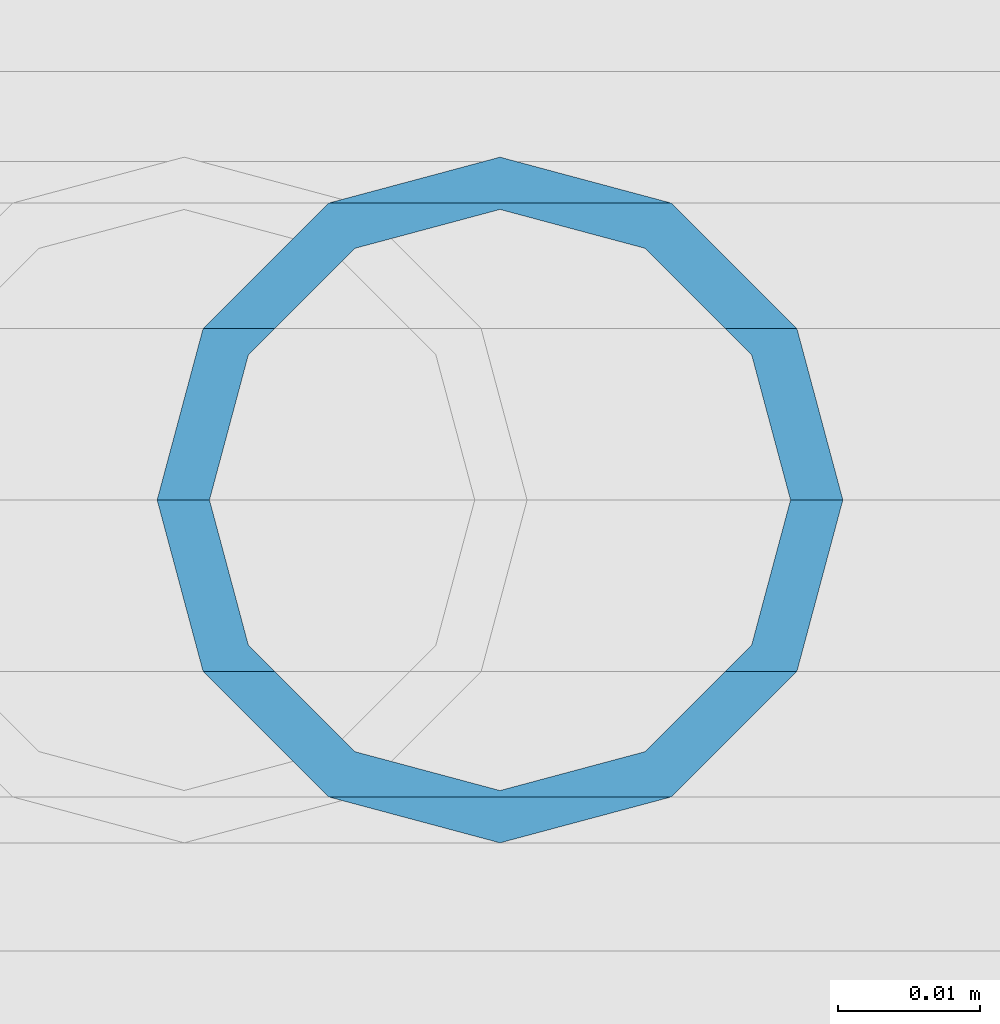
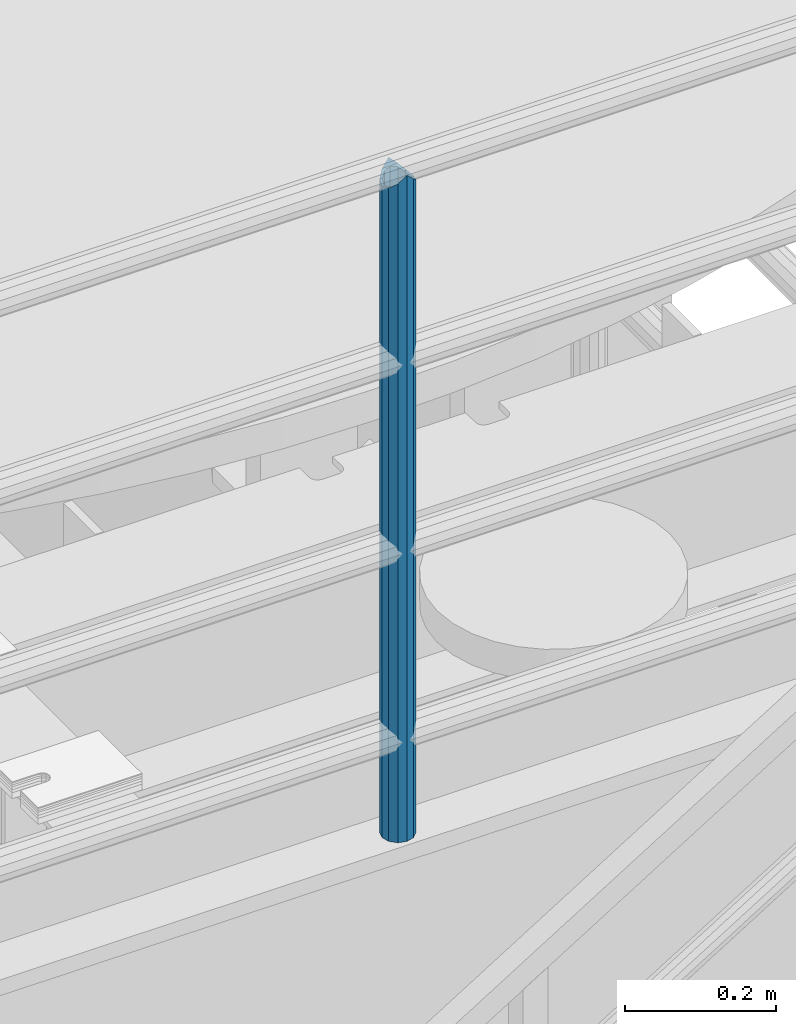
# One storey, part 629 of 1876: 1 column, 1 element without a shape of its own.
"""IFC2X3 building model written with IfcOpenShell, lengths in millimetres."""

from ifc_helpers import new_model, si_unit, frame, origin_with_axes, place, context, subcontext, project, spatial, faceted_brep, material, type_object, element, aggregate, save


model = new_model("IFC2X3")

# Units and contexts
model_context = context("Model", 3, precision=1e-05, world=origin_with_axes())
body_context = subcontext(model_context, "Body", "Model", "MODEL_VIEW")
ifc_project = project(units=[si_unit("LENGTHUNIT", "METRE", prefix="MILLI"), si_unit("AREAUNIT", "SQUARE_METRE"), si_unit("VOLUMEUNIT", "CUBIC_METRE"), si_unit("MASSUNIT", "GRAM", prefix="KILO"), si_unit("TIMEUNIT", "SECOND"), si_unit("PLANEANGLEUNIT", "RADIAN"), si_unit("SOLIDANGLEUNIT", "STERADIAN"), si_unit("THERMODYNAMICTEMPERATUREUNIT", "DEGREE_CELSIUS"), si_unit("LUMINOUSINTENSITYUNIT", "LUMEN")], contexts=[model_context])

# Site, building, storey
site_placement = place(None, origin_with_axes())
site = spatial("IfcSite", under=ifc_project, at=site_placement, CompositionType="ELEMENT")
building_placement = place(site_placement, origin_with_axes())
building = spatial("IfcBuilding", under=site, at=building_placement, Name="Undefined", CompositionType="ELEMENT")
storey_placement = place(building_placement, origin_with_axes())
storey = spatial("IfcBuildingStorey", under=building, at=storey_placement, Name="Undefined", CompositionType="ELEMENT", Elevation=0.0)

# Assembly, column
assembly_placement = place(storey_placement, origin_with_axes())
assembly = element("IfcElementAssembly", 1, at=assembly_placement, inside=storey, Name="RAIL", AssemblyPlace="NOTDEFINED", PredefinedType="RIGID_FRAME")
ifc_material = material()
column_type = type_object("IfcColumnType", Name="PIPE1-1/2SCH40", PredefinedType="NOTDEFINED")
column_placement = place(assembly_placement, frame((3959.22499997645, -4654.55000114554, 17983.2), z_axis=(0.0, 1.0, 0.0), x_axis=(0.0, 0.0, 1.0)))
column = element("IfcColumn", 2, at=column_placement, type_object=column_type, material=ifc_material, Name="POST", ObjectType="PIPE1-1/2SCH40", context=body_context, shape_type="Brep", body=[
    faceted_brep([(1076.325, 0.0, -24.1300000000001), (1064.26, 12.065, -20.8971929933186), (1064.26, -12.0650000000001, -20.8971929933186), (1054.93437856882, 17.7076214311801, 10.2235000000001), (1052.195, 20.4470000000001, 0.0), (1052.195, 24.13, 0.0), (1055.42780700668, 20.8971929933185, 12.0649999999996), (1055.42780700668, 15.8661214311869, 12.0649999999932), (1055.42780700668, 15.8661214311742, -12.065000000006), (1055.42780700668, 20.8971929933185, -12.0649999999996), (1054.93437856882, 17.7076214311801, -10.2235000000001), (1061.07042843786, 10.2235000000001, -17.7076214311801), (1063.80980700668, 0.0, -20.4470000000001), (1061.07042843786, -10.2235000000001, -17.7076214311801), (1055.42780700668, -15.8661214311742, -12.065000000006), (1055.42780700668, -20.8971929933184, -12.0649999999996), (1054.93437856882, -17.7076214311801, -10.2235000000001), (1052.195, -20.4470000000001, 0.0), (1052.195, -24.1300000000001, 0.0), (1054.93437856882, -17.7076214311801, 10.2235000000001), (1055.42780700668, -15.8661214311869, 12.0649999999932), (1055.42780700668, -20.8971929933184, 12.0649999999996), (1076.325, 0.0, 24.1300000000001), (1064.26, -12.0650000000001, 20.8971929933186), (1064.26, 12.065, 20.8971929933186), (1061.07042843787, -10.2235000000001, 17.7076214311801), (1063.80980700669, 0.0, 20.4470000000001), (1061.07042843787, 10.2235000000001, 17.7076214311801), (0.0, -20.8971929933184, -12.0649999999996), (0.0, -12.0650000000001, -20.8971929933186), (-1.45519152283669e-11, 0.0, -24.130000000001), (0.0, 12.0650000000001, -20.8971929933186), (0.0, 20.8971929933184, -12.0649999999996), (0.0, 24.1299999999992, 0.0), (0.0, 20.8971929933184, 12.0649999999996), (0.0, 12.0650000000001, 20.8971929933186), (-1.45519152283669e-11, 0.0, 24.130000000001), (0.0, -20.8971929933184, 12.0649999999996), (0.0, -24.1299999999992, 0.0), (0.0, -12.0650000000001, 20.8971929933186), (0.0, -17.7076214311803, -10.2235000000001), (0.0, -10.2235000000001, -17.7076214311801), (-1.45519152283669e-11, 0.0, -20.4470000000001), (0.0, 10.2235000000001, -17.7076214311801), (0.0, 17.7076214311803, -10.2235000000001), (0.0, 20.4469999999999, 0.0), (0.0, 17.7076214311803, 10.2235000000001), (0.0, 10.2235000000001, 17.7076214311801), (-1.45519152283669e-11, 0.0, 20.4470000000001), (0.0, -10.2235000000001, 17.7076214311801), (0.0, -17.7076214311803, 10.2235000000001), (0.0, -20.4469999999999, 0.0)], [[[0, 1, 2]], [[3, 4, 5, 6, 7]], [[8, 9, 5, 4, 10]], [[2, 1, 9, 8, 11, 12, 13, 14, 15]], [[15, 14, 16, 17, 18]], [[18, 17, 19, 20, 21]], [[22, 23, 24]], [[21, 20, 25, 26, 27, 7, 6, 24, 23]], [[28, 29, 2, 15]], [[29, 30, 0, 2]], [[30, 31, 1, 0]], [[31, 32, 9, 1]], [[32, 33, 5, 9]], [[33, 34, 6, 5]], [[34, 35, 24, 6]], [[35, 36, 22, 24]], [[37, 38, 18, 21]], [[39, 37, 21, 23]], [[36, 39, 23, 22]], [[38, 28, 15, 18]], [[37, 39, 36, 35, 34, 33, 32, 31, 30, 29, 28, 38], [40, 41, 42, 43, 44, 45, 46, 47, 48, 49, 50, 51]], [[49, 48, 26, 25]], [[19, 50, 49, 25, 20]], [[51, 50, 19, 17]], [[40, 51, 17, 16]], [[41, 40, 16, 14, 13]], [[42, 41, 13, 12]], [[43, 42, 12, 11]], [[10, 44, 43, 11, 8]], [[45, 44, 10, 4]], [[46, 45, 4, 3]], [[47, 46, 3, 7, 27]], [[48, 47, 27, 26]]]),
])
aggregate(assembly, [column])

save(model, "model.ifc")
